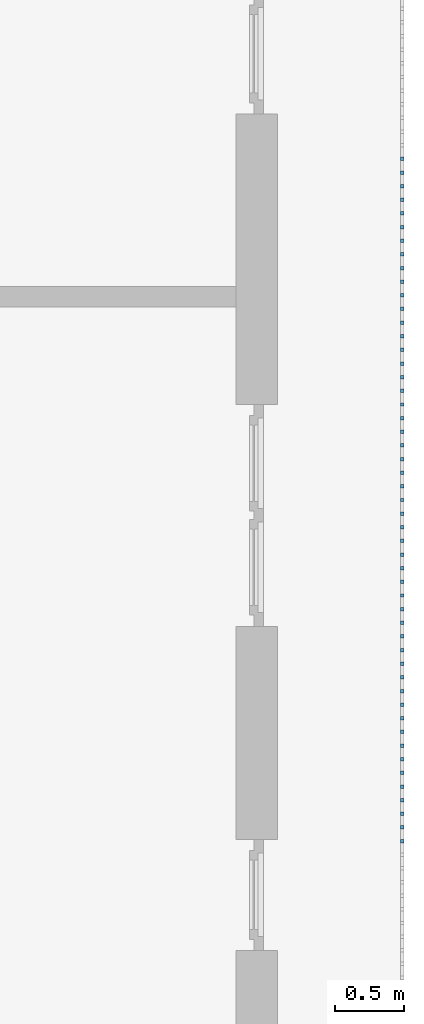
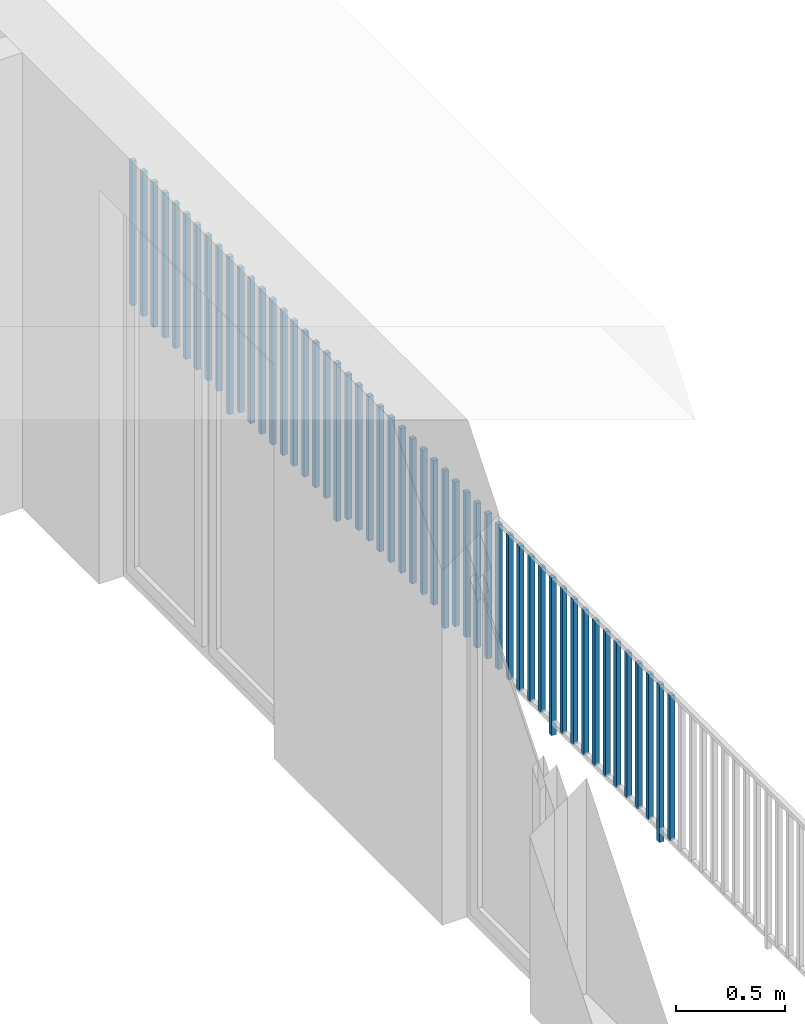
# One storey, part 44 of 54: 51 building element parts, 1 element without a shape of its own.
"""IFC4 building model written with IfcOpenShell, lengths in metres."""

import ifcopenshell
import ifcopenshell.guid

model = None  # the IFC model being written
_history = None  # IfcOwnerHistory: only IFC2X3 demands one
_inside = {}  # id of a spatial element -> (the spatial element, [elements in it])
_under = {}  # id of a project, library or spatial element -> (it, [spatial elements below it])
_declared = {}  # id of a project -> (the project, [libraries it declares])
_typed = {}  # id of a type object -> (the type object, [elements of that type])
_made_of = {}  # id of a material, layer set ... -> (it, [elements and type objects made of it])


def new_model(schema):
    """Start an empty IFC model of exactly this schema.

    Asked for "IFC4X3", IfcOpenShell would pick the latest addendum, in which some entities
    have other attributes; the version numbers below select the first issue.
    IFC2X3 requires an IfcOwnerHistory on every rooted entity: one is made here for all.
    """
    global model, _history
    if schema == "IFC4X3":
        model = ifcopenshell.file(schema_version=(4, 3, 0, 0))
    else:
        model = ifcopenshell.file(schema=schema)
    _inside.clear()
    _under.clear()
    _declared.clear()
    _typed.clear()
    _made_of.clear()
    _history = None
    if model.schema == "IFC2X3":
        org = make("IfcOrganization", Name="unknown")
        user = make(
            "IfcPersonAndOrganization",
            ThePerson=make("IfcPerson", FamilyName="unknown"),
            TheOrganization=org,
        )
        app = make(
            "IfcApplication",
            ApplicationDeveloper=org,
            Version="unknown",
            ApplicationFullName="unknown",
            ApplicationIdentifier="unknown",
        )
        _history = make(
            "IfcOwnerHistory",
            OwningUser=user,
            OwningApplication=app,
            ChangeAction="ADDED",
            CreationDate=0,
        )
    return model


def make(cls, **values):
    """One entity of the class cls with the attributes given. An attribute that is None is left unset."""
    return model.create_entity(
        cls, **{name: value for name, value in values.items() if value is not None}
    )


def entity(cls, *values):
    """Any entity or typed value of the class cls, its attributes in the order of the schema. None: left unset."""
    e = model.create_entity(cls)
    for i, value in enumerate(values):
        if value is not None:
            e[i] = value
    return e


def rooted(cls, **values):
    """An entity with a GlobalId (a new one), such as an element, a storey or a relation."""
    return make(cls, GlobalId=ifcopenshell.guid.new(), OwnerHistory=_history, **values)


def si_unit(unit_type, name, prefix=None):
    """IfcSIUnit, for example si_unit("LENGTHUNIT", "METRE", prefix="MILLI")."""
    return make("IfcSIUnit", UnitType=unit_type, Prefix=prefix, Name=name)


def converted_unit(unit_type, name, factor, base, dimensions=None, offset=None):
    """IfcConversionBasedUnit, such as the inch: factor (a typed value) times the base unit."""
    return make(
        "IfcConversionBasedUnit"
        if offset is None
        else "IfcConversionBasedUnitWithOffset",
        ConversionOffset=offset,
        Dimensions=None
        if dimensions is None
        else entity("IfcDimensionalExponents", *dimensions),
        UnitType=unit_type,
        Name=name,
        ConversionFactor=make(
            "IfcMeasureWithUnit", ValueComponent=factor, UnitComponent=base
        ),
    )


def derived_unit(unit_type, elements):
    """IfcDerivedUnit: a product of units, each with its exponent."""
    return make(
        "IfcDerivedUnit",
        Elements=[
            make("IfcDerivedUnitElement", Unit=unit, Exponent=power)
            for unit, power in elements
        ],
        UnitType=unit_type,
    )


def assignment(units):
    """IfcUnitAssignment: the units of a project."""
    return None if units is None else make("IfcUnitAssignment", Units=units)


def point(xyz):
    """IfcCartesianPoint."""
    return None if xyz is None else make("IfcCartesianPoint", Coordinates=xyz)


def direction(xyz):
    """IfcDirection."""
    return None if xyz is None else make("IfcDirection", DirectionRatios=xyz)


def frame(location, z_axis=None, x_axis=None):
    """IfcAxis2Placement3D, a coordinate frame: its origin and axes. An axis left out is left unset."""
    return make(
        "IfcAxis2Placement3D",
        Location=point(location),
        Axis=direction(z_axis),
        RefDirection=direction(x_axis),
    )


def origin_with_axes():
    """The frame at (0, 0, 0) with the z axis (0, 0, 1) and the x axis (1, 0, 0) written out."""
    return frame((0.0, 0.0, 0.0), z_axis=(0.0, 0.0, 1.0), x_axis=(1.0, 0.0, 0.0))


def place(relative_to, where):
    """IfcLocalPlacement: puts the frame where relative to a parent placement (None: the world)."""
    return make(
        "IfcLocalPlacement", PlacementRelTo=relative_to, RelativePlacement=where
    )


def context(
    kind, dimensions, precision=None, world=None, true_north=None, identifier=None
):
    """IfcGeometricRepresentationContext, for example the 3D "Model" context."""
    return make(
        "IfcGeometricRepresentationContext",
        ContextIdentifier=identifier,
        ContextType=kind,
        CoordinateSpaceDimension=dimensions,
        Precision=precision,
        WorldCoordinateSystem=world,
        TrueNorth=true_north,
    )


def subcontext(parent, identifier, kind, view, scale=None):
    """IfcGeometricRepresentationSubContext, for example "Body" below "Model"."""
    return make(
        "IfcGeometricRepresentationSubContext",
        ContextIdentifier=identifier,
        ContextType=kind,
        ParentContext=parent,
        TargetScale=scale,
        TargetView=view,
    )


def project(units=None, contexts=None):
    """IfcProject with its units and contexts."""
    return rooted(
        "IfcProject",
        Name="project",
        RepresentationContexts=contexts,
        UnitsInContext=assignment(units),
    )


def spatial(cls, under=None, at=None, **own):
    """A site, building, storey or space (cls), placed at a placement, below another one or the project."""
    s = rooted(cls, ObjectPlacement=at, **own)
    if under is not None:
        _under.setdefault(under.id(), (under, []))[1].append(s)
    return s


def point_list(points):
    """IfcCartesianPointList2D or 3D."""
    cls = (
        "IfcCartesianPointList2D" if len(points[0]) == 2 else "IfcCartesianPointList3D"
    )
    return make(cls, CoordList=points)


def polygons(points, faces, closed=None, point_numbers=None):
    """IfcPolygonalFaceSet: a face is its outer loop, then its inner loops; points numbered from 1."""
    made = []
    for loops in faces:
        if len(loops) == 1:
            made.append(make("IfcIndexedPolygonalFace", CoordIndex=loops[0]))
        else:
            made.append(
                make(
                    "IfcIndexedPolygonalFaceWithVoids",
                    CoordIndex=loops[0],
                    InnerCoordIndices=loops[1:],
                )
            )
    return make(
        "IfcPolygonalFaceSet",
        Coordinates=point_list(points),
        Closed=closed,
        Faces=made,
        PnIndex=point_numbers,
    )


def shape(context_of_items, identifier, shape_type, items):
    """IfcShapeRepresentation: the items that make up one representation, for example the "Body"."""
    return make(
        "IfcShapeRepresentation",
        ContextOfItems=context_of_items,
        RepresentationIdentifier=identifier,
        RepresentationType=shape_type,
        Items=items,
    )


def material(Name=None, Category=None):
    """IfcMaterial."""
    return make("IfcMaterial", Name=Name, Category=Category)


def made_of(thing, what):
    """Note that an element or type object is made of a material, layer set ...; save() writes the relation."""
    if what is not None:
        _made_of.setdefault(what.id(), (what, []))[1].append(thing)
    return thing


def type_object(cls, material=None, **own):
    """A type object (cls), such as IfcWallType, which elements share."""
    return made_of(rooted(cls, **own), material)


def element(
    cls,
    number,
    at=None,
    inside=None,
    cuts=None,
    type_object=None,
    material=None,
    context=None,
    identifier="Body",
    shape_type=None,
    held_by="IfcProductDefinitionShape",
    body=None,
    shapes=None,
    **own,
):
    """One element of the class cls, such as IfcWall. Its Tag is "e" and its number.

    at: its placement. inside: the storey or other place that contains it. cuts: it is an
    opening in that element (IfcRelVoidsElement). A single representation is given by context,
    identifier, shape_type and body (its items); several are given by shapes. held_by: the class
    of the entity that holds the representations. save() writes the other relations.
    """
    e = rooted(cls, Tag="e%d" % number, ObjectPlacement=at, **own)
    if body is not None:
        shapes = [shape(context, identifier, shape_type, body)]
    if shapes is not None:
        e.Representation = make(held_by, Representations=shapes)
    if inside is not None:
        _inside.setdefault(inside.id(), (inside, []))[1].append(e)
    if cuts is not None:
        rooted(
            "IfcRelVoidsElement", RelatingBuildingElement=cuts, RelatedOpeningElement=e
        )
    if type_object is not None:
        _typed.setdefault(type_object.id(), (type_object, []))[1].append(e)
    return made_of(e, material)


def aggregate(whole, parts):
    """IfcRelAggregates: a whole, such as a stair, and the parts it consists of."""
    return rooted("IfcRelAggregates", RelatingObject=whole, RelatedObjects=parts)


def save(model, path):
    """Write the relations noted so far, then the file.

    IfcRelAggregates (storeys below a building ...), IfcRelContainedInSpatialStructure (elements
    in a storey), IfcRelDefinesByType, IfcRelAssociatesMaterial and IfcRelDeclares: one each for
    every whole, place, type object, material and project.
    """
    for whole, parts in _under.values():
        aggregate(whole, parts)
    for where, things in _inside.values():
        rooted(
            "IfcRelContainedInSpatialStructure",
            RelatedElements=things,
            RelatingStructure=where,
        )
    for kind, things in _typed.values():
        rooted("IfcRelDefinesByType", RelatedObjects=things, RelatingType=kind)
    for what, things in _made_of.values():
        rooted("IfcRelAssociatesMaterial", RelatedObjects=things, RelatingMaterial=what)
    for by, libraries in _declared.values():
        rooted("IfcRelDeclares", RelatingContext=by, RelatedDefinitions=libraries)
    model.write(path)


model = new_model("IFC4")

# Units and contexts
model_context = context("Model", 3, precision=1e-05, world=origin_with_axes(), true_north=direction((0.0, 1.0)))
body_context = subcontext(model_context, "Body", "Model", "MODEL_VIEW")
ifc_project = project(units=[si_unit("LENGTHUNIT", "METRE"), si_unit("AREAUNIT", "SQUARE_METRE"), si_unit("VOLUMEUNIT", "CUBIC_METRE"), converted_unit("PLANEANGLEUNIT", "DEGREE", entity("IfcPlaneAngleMeasure", 0.0174532925199), si_unit("PLANEANGLEUNIT", "RADIAN"), dimensions=[0, 0, 0, 0, 0, 0, 0]), converted_unit("TIMEUNIT", "Year", entity("IfcTimeMeasure", 31556926.0), si_unit("TIMEUNIT", "SECOND"), dimensions=[0, 0, 1, 0, 0, 0, 0]), si_unit("MASSUNIT", "GRAM", prefix="KILO"), si_unit("THERMODYNAMICTEMPERATUREUNIT", "DEGREE_CELSIUS"), si_unit("LUMINOUSINTENSITYUNIT", "LUMEN"), si_unit("ENERGYUNIT", "JOULE", prefix="MEGA"), derived_unit("THERMALCONDUCTANCEUNIT", [(si_unit("POWERUNIT", "WATT"), 1), (si_unit("LENGTHUNIT", "METRE"), -1), (si_unit("THERMODYNAMICTEMPERATUREUNIT", "KELVIN"), -1)]), derived_unit("SPECIFICHEATCAPACITYUNIT", [(si_unit("ENERGYUNIT", "JOULE"), 1), (si_unit("MASSUNIT", "GRAM", prefix="KILO"), -1), (si_unit("THERMODYNAMICTEMPERATUREUNIT", "KELVIN"), -1)]), derived_unit("MASSDENSITYUNIT", [(si_unit("MASSUNIT", "GRAM", prefix="KILO"), 1), (si_unit("VOLUMEUNIT", "CUBIC_METRE"), -1)])], contexts=[model_context])

# Site, building, storey, space
site_placement = place(None, origin_with_axes())
site = spatial("IfcSite", under=ifc_project, at=site_placement, CompositionType="ELEMENT")
building_placement = place(site_placement, origin_with_axes())
building = spatial("IfcBuilding", under=site, at=building_placement, CompositionType="ELEMENT")
storey_placement = place(building_placement, frame((0.0, 0.0, 6.29), z_axis=(0.0, 0.0, 1.0), x_axis=(1.0, 0.0, 0.0)))
storey = spatial("IfcBuildingStorey", under=building, at=storey_placement, Name="2. Geschoss", CompositionType="ELEMENT", Elevation=6.29)
space_placement = place(storey_placement, frame((10.2378006196, 9.82118769833, 0.0), z_axis=(0.0, 0.0, 1.0), x_axis=(-1.0, 0.0, 0.0)))
space = spatial("IfcSpace", under=storey, at=space_placement, CompositionType="ELEMENT", PredefinedType="EXTERNAL")

# Railing, building element parts
railing_type = type_object("IfcRailingType", PredefinedType="NOTDEFINED")
railing_placement = place(space_placement, frame((0.0, -7.06315681498e-08, 0.0), z_axis=(0.0, 0.0, 1.0), x_axis=(-1.0, 0.0, 0.0)))
railing = element("IfcRailing", 1, at=railing_placement, inside=space, type_object=railing_type, PredefinedType="NOTDEFINED")
ifc_material = material()
building_element_part_1_placement = place(railing_placement, origin_with_axes())
building_element_part_1 = element("IfcBuildingElementPart", 2, at=building_element_part_1_placement, material=ifc_material, PredefinedType="NOTDEFINED", context=body_context, shape_type="Tessellation", body=[
    polygons([(0.0125, -17.7858333333, 0.07), (-0.0125, -17.7858333333, 0.07), (-0.0125, -17.7858333333, 0.8775), (0.0125, -17.7858333333, 0.8775), (0.0125, -17.8108333333, 0.07), (-0.0125, -17.8108333333, 0.07), (-0.0125, -17.8108333333, 0.8775), (0.0125, -17.8108333333, 0.8775)], [[[1, 2, 3, 4]], [[1, 5, 6, 2]], [[2, 6, 7, 3]], [[4, 3, 7, 8]], [[5, 1, 4, 8]], [[6, 5, 8, 7]]], closed=True),
])
building_element_part_2_placement = place(railing_placement, origin_with_axes())
building_element_part_2 = element("IfcBuildingElementPart", 3, at=building_element_part_2_placement, material=ifc_material, PredefinedType="NOTDEFINED", context=body_context, shape_type="Tessellation", body=[
    polygons([(0.0125, -17.6875, 0.0), (-0.0125, -17.6875, 0.0), (-0.0125, -17.6875, 0.88), (0.0125, -17.6875, 0.88), (0.0125, -17.7125, 0.0), (-0.0125, -17.7125, 0.0), (-0.0125, -17.7125, 0.88), (0.0125, -17.7125, 0.88)], [[[1, 2, 3, 4]], [[1, 5, 6, 2]], [[2, 6, 7, 3]], [[4, 3, 7, 8]], [[5, 1, 4, 8]], [[6, 5, 8, 7]]], closed=True),
])
building_element_part_3_placement = place(railing_placement, origin_with_axes())
building_element_part_3 = element("IfcBuildingElementPart", 4, at=building_element_part_3_placement, material=ifc_material, PredefinedType="NOTDEFINED", context=body_context, shape_type="Tessellation", body=[
    polygons([(0.0125, -17.5891666667, 0.07), (-0.0125, -17.5891666667, 0.07), (-0.0125, -17.5891666667, 0.8775), (0.0125, -17.5891666667, 0.8775), (0.0125, -17.6141666667, 0.07), (-0.0125, -17.6141666667, 0.07), (-0.0125, -17.6141666667, 0.8775), (0.0125, -17.6141666667, 0.8775)], [[[1, 2, 3, 4]], [[1, 5, 6, 2]], [[2, 6, 7, 3]], [[4, 3, 7, 8]], [[5, 1, 4, 8]], [[6, 5, 8, 7]]], closed=True),
])
building_element_part_4_placement = place(railing_placement, origin_with_axes())
building_element_part_4 = element("IfcBuildingElementPart", 5, at=building_element_part_4_placement, material=ifc_material, PredefinedType="NOTDEFINED", context=body_context, shape_type="Tessellation", body=[
    polygons([(0.0125, -17.4908333333, 0.07), (-0.0125, -17.4908333333, 0.07), (-0.0125, -17.4908333333, 0.8775), (0.0125, -17.4908333333, 0.8775), (0.0125, -17.5158333333, 0.07), (-0.0125, -17.5158333333, 0.07), (-0.0125, -17.5158333333, 0.8775), (0.0125, -17.5158333333, 0.8775)], [[[1, 2, 3, 4]], [[1, 5, 6, 2]], [[2, 6, 7, 3]], [[4, 3, 7, 8]], [[5, 1, 4, 8]], [[6, 5, 8, 7]]], closed=True),
])
building_element_part_5_placement = place(railing_placement, origin_with_axes())
building_element_part_5 = element("IfcBuildingElementPart", 6, at=building_element_part_5_placement, material=ifc_material, PredefinedType="NOTDEFINED", context=body_context, shape_type="Tessellation", body=[
    polygons([(0.0125, -17.3925, 0.07), (-0.0125, -17.3925, 0.07), (-0.0125, -17.3925, 0.8775), (0.0125, -17.3925, 0.8775), (0.0125, -17.4175, 0.07), (-0.0125, -17.4175, 0.07), (-0.0125, -17.4175, 0.8775), (0.0125, -17.4175, 0.8775)], [[[1, 2, 3, 4]], [[1, 5, 6, 2]], [[2, 6, 7, 3]], [[4, 3, 7, 8]], [[5, 1, 4, 8]], [[6, 5, 8, 7]]], closed=True),
])
building_element_part_6_placement = place(railing_placement, origin_with_axes())
building_element_part_6 = element("IfcBuildingElementPart", 7, at=building_element_part_6_placement, material=ifc_material, PredefinedType="NOTDEFINED", context=body_context, shape_type="Tessellation", body=[
    polygons([(0.0125, -17.2941666667, 0.07), (-0.0125, -17.2941666667, 0.07), (-0.0125, -17.2941666667, 0.8775), (0.0125, -17.2941666667, 0.8775), (0.0125, -17.3191666667, 0.07), (-0.0125, -17.3191666667, 0.07), (-0.0125, -17.3191666667, 0.8775), (0.0125, -17.3191666667, 0.8775)], [[[1, 2, 3, 4]], [[1, 5, 6, 2]], [[2, 6, 7, 3]], [[4, 3, 7, 8]], [[5, 1, 4, 8]], [[6, 5, 8, 7]]], closed=True),
])
building_element_part_7_placement = place(railing_placement, origin_with_axes())
building_element_part_7 = element("IfcBuildingElementPart", 8, at=building_element_part_7_placement, material=ifc_material, PredefinedType="NOTDEFINED", context=body_context, shape_type="Tessellation", body=[
    polygons([(0.0125, -17.1958333333, 0.07), (-0.0125, -17.1958333333, 0.07), (-0.0125, -17.1958333333, 0.8775), (0.0125, -17.1958333333, 0.8775), (0.0125, -17.2208333333, 0.07), (-0.0125, -17.2208333333, 0.07), (-0.0125, -17.2208333333, 0.8775), (0.0125, -17.2208333333, 0.8775)], [[[1, 2, 3, 4]], [[1, 5, 6, 2]], [[2, 6, 7, 3]], [[4, 3, 7, 8]], [[5, 1, 4, 8]], [[6, 5, 8, 7]]], closed=True),
])
building_element_part_8_placement = place(railing_placement, origin_with_axes())
building_element_part_8 = element("IfcBuildingElementPart", 9, at=building_element_part_8_placement, material=ifc_material, PredefinedType="NOTDEFINED", context=body_context, shape_type="Tessellation", body=[
    polygons([(0.0125, -17.0975, 0.07), (-0.0125, -17.0975, 0.07), (-0.0125, -17.0975, 0.8775), (0.0125, -17.0975, 0.8775), (0.0125, -17.1225, 0.07), (-0.0125, -17.1225, 0.07), (-0.0125, -17.1225, 0.8775), (0.0125, -17.1225, 0.8775)], [[[1, 2, 3, 4]], [[1, 5, 6, 2]], [[2, 6, 7, 3]], [[4, 3, 7, 8]], [[5, 1, 4, 8]], [[6, 5, 8, 7]]], closed=True),
])
building_element_part_9_placement = place(railing_placement, origin_with_axes())
building_element_part_9 = element("IfcBuildingElementPart", 10, at=building_element_part_9_placement, material=ifc_material, PredefinedType="NOTDEFINED", context=body_context, shape_type="Tessellation", body=[
    polygons([(0.0125, -16.9991666667, 0.07), (-0.0125, -16.9991666667, 0.07), (-0.0125, -16.9991666667, 0.8775), (0.0125, -16.9991666667, 0.8775), (0.0125, -17.0241666667, 0.07), (-0.0125, -17.0241666667, 0.07), (-0.0125, -17.0241666667, 0.8775), (0.0125, -17.0241666667, 0.8775)], [[[1, 2, 3, 4]], [[1, 5, 6, 2]], [[2, 6, 7, 3]], [[4, 3, 7, 8]], [[5, 1, 4, 8]], [[6, 5, 8, 7]]], closed=True),
])
building_element_part_10_placement = place(railing_placement, origin_with_axes())
building_element_part_10 = element("IfcBuildingElementPart", 11, at=building_element_part_10_placement, material=ifc_material, PredefinedType="NOTDEFINED", context=body_context, shape_type="Tessellation", body=[
    polygons([(0.0125, -16.9008333333, 0.07), (-0.0125, -16.9008333333, 0.07), (-0.0125, -16.9008333333, 0.8775), (0.0125, -16.9008333333, 0.8775), (0.0125, -16.9258333333, 0.07), (-0.0125, -16.9258333333, 0.07), (-0.0125, -16.9258333333, 0.8775), (0.0125, -16.9258333333, 0.8775)], [[[1, 2, 3, 4]], [[1, 5, 6, 2]], [[2, 6, 7, 3]], [[4, 3, 7, 8]], [[5, 1, 4, 8]], [[6, 5, 8, 7]]], closed=True),
])
building_element_part_11_placement = place(railing_placement, origin_with_axes())
building_element_part_11 = element("IfcBuildingElementPart", 12, at=building_element_part_11_placement, material=ifc_material, PredefinedType="NOTDEFINED", context=body_context, shape_type="Tessellation", body=[
    polygons([(0.0125, -16.8025, 0.07), (-0.0125, -16.8025, 0.07), (-0.0125, -16.8025, 0.8775), (0.0125, -16.8025, 0.8775), (0.0125, -16.8275, 0.07), (-0.0125, -16.8275, 0.07), (-0.0125, -16.8275, 0.8775), (0.0125, -16.8275, 0.8775)], [[[1, 2, 3, 4]], [[1, 5, 6, 2]], [[2, 6, 7, 3]], [[4, 3, 7, 8]], [[5, 1, 4, 8]], [[6, 5, 8, 7]]], closed=True),
])
building_element_part_12_placement = place(railing_placement, origin_with_axes())
building_element_part_12 = element("IfcBuildingElementPart", 13, at=building_element_part_12_placement, material=ifc_material, PredefinedType="NOTDEFINED", context=body_context, shape_type="Tessellation", body=[
    polygons([(0.0125, -16.7041666667, 0.0), (-0.0125, -16.7041666667, 0.0), (-0.0125, -16.7041666667, 0.88), (0.0125, -16.7041666667, 0.88), (0.0125, -16.7291666667, 0.0), (-0.0125, -16.7291666667, 0.0), (-0.0125, -16.7291666667, 0.88), (0.0125, -16.7291666667, 0.88)], [[[1, 2, 3, 4]], [[1, 5, 6, 2]], [[2, 6, 7, 3]], [[4, 3, 7, 8]], [[5, 1, 4, 8]], [[6, 5, 8, 7]]], closed=True),
])
building_element_part_13_placement = place(railing_placement, origin_with_axes())
building_element_part_13 = element("IfcBuildingElementPart", 14, at=building_element_part_13_placement, material=ifc_material, PredefinedType="NOTDEFINED", context=body_context, shape_type="Tessellation", body=[
    polygons([(0.0125, -16.6058333333, 0.07), (-0.0125, -16.6058333333, 0.07), (-0.0125, -16.6058333333, 0.8775), (0.0125, -16.6058333333, 0.8775), (0.0125, -16.6308333333, 0.07), (-0.0125, -16.6308333333, 0.07), (-0.0125, -16.6308333333, 0.8775), (0.0125, -16.6308333333, 0.8775)], [[[1, 2, 3, 4]], [[1, 5, 6, 2]], [[2, 6, 7, 3]], [[4, 3, 7, 8]], [[5, 1, 4, 8]], [[6, 5, 8, 7]]], closed=True),
])
building_element_part_14_placement = place(railing_placement, origin_with_axes())
building_element_part_14 = element("IfcBuildingElementPart", 15, at=building_element_part_14_placement, material=ifc_material, PredefinedType="NOTDEFINED", context=body_context, shape_type="Tessellation", body=[
    polygons([(0.0125, -16.5075, 0.07), (-0.0125, -16.5075, 0.07), (-0.0125, -16.5075, 0.8775), (0.0125, -16.5075, 0.8775), (0.0125, -16.5325, 0.07), (-0.0125, -16.5325, 0.07), (-0.0125, -16.5325, 0.8775), (0.0125, -16.5325, 0.8775)], [[[1, 2, 3, 4]], [[1, 5, 6, 2]], [[2, 6, 7, 3]], [[4, 3, 7, 8]], [[5, 1, 4, 8]], [[6, 5, 8, 7]]], closed=True),
])
building_element_part_15_placement = place(railing_placement, origin_with_axes())
building_element_part_15 = element("IfcBuildingElementPart", 16, at=building_element_part_15_placement, material=ifc_material, PredefinedType="NOTDEFINED", context=body_context, shape_type="Tessellation", body=[
    polygons([(0.0125, -16.4091666667, 0.07), (-0.0125, -16.4091666667, 0.07), (-0.0125, -16.4091666667, 0.8775), (0.0125, -16.4091666667, 0.8775), (0.0125, -16.4341666667, 0.07), (-0.0125, -16.4341666667, 0.07), (-0.0125, -16.4341666667, 0.8775), (0.0125, -16.4341666667, 0.8775)], [[[1, 2, 3, 4]], [[1, 5, 6, 2]], [[2, 6, 7, 3]], [[4, 3, 7, 8]], [[5, 1, 4, 8]], [[6, 5, 8, 7]]], closed=True),
])
building_element_part_16_placement = place(railing_placement, origin_with_axes())
building_element_part_16 = element("IfcBuildingElementPart", 17, at=building_element_part_16_placement, material=ifc_material, PredefinedType="NOTDEFINED", context=body_context, shape_type="Tessellation", body=[
    polygons([(0.0125, -16.3108333333, 0.07), (-0.0125, -16.3108333333, 0.07), (-0.0125, -16.3108333333, 0.8775), (0.0125, -16.3108333333, 0.8775), (0.0125, -16.3358333333, 0.07), (-0.0125, -16.3358333333, 0.07), (-0.0125, -16.3358333333, 0.8775), (0.0125, -16.3358333333, 0.8775)], [[[1, 2, 3, 4]], [[1, 5, 6, 2]], [[2, 6, 7, 3]], [[4, 3, 7, 8]], [[5, 1, 4, 8]], [[6, 5, 8, 7]]], closed=True),
])
building_element_part_17_placement = place(railing_placement, origin_with_axes())
building_element_part_17 = element("IfcBuildingElementPart", 18, at=building_element_part_17_placement, material=ifc_material, PredefinedType="NOTDEFINED", context=body_context, shape_type="Tessellation", body=[
    polygons([(0.0125, -16.2125, 0.07), (-0.0125, -16.2125, 0.07), (-0.0125, -16.2125, 0.8775), (0.0125, -16.2125, 0.8775), (0.0125, -16.2375, 0.07), (-0.0125, -16.2375, 0.07), (-0.0125, -16.2375, 0.8775), (0.0125, -16.2375, 0.8775)], [[[1, 2, 3, 4]], [[1, 5, 6, 2]], [[2, 6, 7, 3]], [[4, 3, 7, 8]], [[5, 1, 4, 8]], [[6, 5, 8, 7]]], closed=True),
])
building_element_part_18_placement = place(railing_placement, origin_with_axes())
building_element_part_18 = element("IfcBuildingElementPart", 19, at=building_element_part_18_placement, material=ifc_material, PredefinedType="NOTDEFINED", context=body_context, shape_type="Tessellation", body=[
    polygons([(0.0125, -16.1141666667, 0.07), (-0.0125, -16.1141666667, 0.07), (-0.0125, -16.1141666667, 0.8775), (0.0125, -16.1141666667, 0.8775), (0.0125, -16.1391666667, 0.07), (-0.0125, -16.1391666667, 0.07), (-0.0125, -16.1391666667, 0.8775), (0.0125, -16.1391666667, 0.8775)], [[[1, 2, 3, 4]], [[1, 5, 6, 2]], [[2, 6, 7, 3]], [[4, 3, 7, 8]], [[5, 1, 4, 8]], [[6, 5, 8, 7]]], closed=True),
])
building_element_part_19_placement = place(railing_placement, origin_with_axes())
building_element_part_19 = element("IfcBuildingElementPart", 20, at=building_element_part_19_placement, material=ifc_material, PredefinedType="NOTDEFINED", context=body_context, shape_type="Tessellation", body=[
    polygons([(0.0125, -16.0158333333, 0.07), (-0.0125, -16.0158333333, 0.07), (-0.0125, -16.0158333333, 0.8775), (0.0125, -16.0158333333, 0.8775), (0.0125, -16.0408333333, 0.07), (-0.0125, -16.0408333333, 0.07), (-0.0125, -16.0408333333, 0.8775), (0.0125, -16.0408333333, 0.8775)], [[[1, 2, 3, 4]], [[1, 5, 6, 2]], [[2, 6, 7, 3]], [[4, 3, 7, 8]], [[5, 1, 4, 8]], [[6, 5, 8, 7]]], closed=True),
])
building_element_part_20_placement = place(railing_placement, origin_with_axes())
building_element_part_20 = element("IfcBuildingElementPart", 21, at=building_element_part_20_placement, material=ifc_material, PredefinedType="NOTDEFINED", context=body_context, shape_type="Tessellation", body=[
    polygons([(0.0125, -15.9175, 0.07), (-0.0125, -15.9175, 0.07), (-0.0125, -15.9175, 0.8775), (0.0125, -15.9175, 0.8775), (0.0125, -15.9425, 0.07), (-0.0125, -15.9425, 0.07), (-0.0125, -15.9425, 0.8775), (0.0125, -15.9425, 0.8775)], [[[1, 2, 3, 4]], [[1, 5, 6, 2]], [[2, 6, 7, 3]], [[4, 3, 7, 8]], [[5, 1, 4, 8]], [[6, 5, 8, 7]]], closed=True),
])
building_element_part_21_placement = place(railing_placement, origin_with_axes())
building_element_part_21 = element("IfcBuildingElementPart", 22, at=building_element_part_21_placement, material=ifc_material, PredefinedType="NOTDEFINED", context=body_context, shape_type="Tessellation", body=[
    polygons([(0.0125, -15.8191666667, 0.07), (-0.0125, -15.8191666667, 0.07), (-0.0125, -15.8191666667, 0.8775), (0.0125, -15.8191666667, 0.8775), (0.0125, -15.8441666667, 0.07), (-0.0125, -15.8441666667, 0.07), (-0.0125, -15.8441666667, 0.8775), (0.0125, -15.8441666667, 0.8775)], [[[1, 2, 3, 4]], [[1, 5, 6, 2]], [[2, 6, 7, 3]], [[4, 3, 7, 8]], [[5, 1, 4, 8]], [[6, 5, 8, 7]]], closed=True),
])
building_element_part_22_placement = place(railing_placement, origin_with_axes())
building_element_part_22 = element("IfcBuildingElementPart", 23, at=building_element_part_22_placement, material=ifc_material, PredefinedType="NOTDEFINED", context=body_context, shape_type="Tessellation", body=[
    polygons([(0.0125, -15.7208333333, 0.0), (-0.0125, -15.7208333333, 0.0), (-0.0125, -15.7208333333, 0.88), (0.0125, -15.7208333333, 0.88), (0.0125, -15.7458333333, 0.0), (-0.0125, -15.7458333333, 0.0), (-0.0125, -15.7458333333, 0.88), (0.0125, -15.7458333333, 0.88)], [[[1, 2, 3, 4]], [[1, 5, 6, 2]], [[2, 6, 7, 3]], [[4, 3, 7, 8]], [[5, 1, 4, 8]], [[6, 5, 8, 7]]], closed=True),
])
building_element_part_23_placement = place(railing_placement, origin_with_axes())
building_element_part_23 = element("IfcBuildingElementPart", 24, at=building_element_part_23_placement, material=ifc_material, PredefinedType="NOTDEFINED", context=body_context, shape_type="Tessellation", body=[
    polygons([(0.0125, -15.6225, 0.07), (-0.0125, -15.6225, 0.07), (-0.0125, -15.6225, 0.8775), (0.0125, -15.6225, 0.8775), (0.0125, -15.6475, 0.07), (-0.0125, -15.6475, 0.07), (-0.0125, -15.6475, 0.8775), (0.0125, -15.6475, 0.8775)], [[[1, 2, 3, 4]], [[1, 5, 6, 2]], [[2, 6, 7, 3]], [[4, 3, 7, 8]], [[5, 1, 4, 8]], [[6, 5, 8, 7]]], closed=True),
])
building_element_part_24_placement = place(railing_placement, origin_with_axes())
building_element_part_24 = element("IfcBuildingElementPart", 25, at=building_element_part_24_placement, material=ifc_material, PredefinedType="NOTDEFINED", context=body_context, shape_type="Tessellation", body=[
    polygons([(0.0125, -15.5241666667, 0.07), (-0.0125, -15.5241666667, 0.07), (-0.0125, -15.5241666667, 0.8775), (0.0125, -15.5241666667, 0.8775), (0.0125, -15.5491666667, 0.07), (-0.0125, -15.5491666667, 0.07), (-0.0125, -15.5491666667, 0.8775), (0.0125, -15.5491666667, 0.8775)], [[[1, 2, 3, 4]], [[1, 5, 6, 2]], [[2, 6, 7, 3]], [[4, 3, 7, 8]], [[5, 1, 4, 8]], [[6, 5, 8, 7]]], closed=True),
])
building_element_part_25_placement = place(railing_placement, origin_with_axes())
building_element_part_25 = element("IfcBuildingElementPart", 26, at=building_element_part_25_placement, material=ifc_material, PredefinedType="NOTDEFINED", context=body_context, shape_type="Tessellation", body=[
    polygons([(0.0125, -15.4258333333, 0.07), (-0.0125, -15.4258333333, 0.07), (-0.0125, -15.4258333333, 0.8775), (0.0125, -15.4258333333, 0.8775), (0.0125, -15.4508333333, 0.07), (-0.0125, -15.4508333333, 0.07), (-0.0125, -15.4508333333, 0.8775), (0.0125, -15.4508333333, 0.8775)], [[[1, 2, 3, 4]], [[1, 5, 6, 2]], [[2, 6, 7, 3]], [[4, 3, 7, 8]], [[5, 1, 4, 8]], [[6, 5, 8, 7]]], closed=True),
])
building_element_part_26_placement = place(railing_placement, origin_with_axes())
building_element_part_26 = element("IfcBuildingElementPart", 27, at=building_element_part_26_placement, material=ifc_material, PredefinedType="NOTDEFINED", context=body_context, shape_type="Tessellation", body=[
    polygons([(0.0125, -15.3275, 0.07), (-0.0125, -15.3275, 0.07), (-0.0125, -15.3275, 0.8775), (0.0125, -15.3275, 0.8775), (0.0125, -15.3525, 0.07), (-0.0125, -15.3525, 0.07), (-0.0125, -15.3525, 0.8775), (0.0125, -15.3525, 0.8775)], [[[1, 2, 3, 4]], [[1, 5, 6, 2]], [[2, 6, 7, 3]], [[4, 3, 7, 8]], [[5, 1, 4, 8]], [[6, 5, 8, 7]]], closed=True),
])
building_element_part_27_placement = place(railing_placement, origin_with_axes())
building_element_part_27 = element("IfcBuildingElementPart", 28, at=building_element_part_27_placement, material=ifc_material, PredefinedType="NOTDEFINED", context=body_context, shape_type="Tessellation", body=[
    polygons([(0.0125, -15.2291666667, 0.07), (-0.0125, -15.2291666667, 0.07), (-0.0125, -15.2291666667, 0.8775), (0.0125, -15.2291666667, 0.8775), (0.0125, -15.2541666667, 0.07), (-0.0125, -15.2541666667, 0.07), (-0.0125, -15.2541666667, 0.8775), (0.0125, -15.2541666667, 0.8775)], [[[1, 2, 3, 4]], [[1, 5, 6, 2]], [[2, 6, 7, 3]], [[4, 3, 7, 8]], [[5, 1, 4, 8]], [[6, 5, 8, 7]]], closed=True),
])
building_element_part_28_placement = place(railing_placement, origin_with_axes())
building_element_part_28 = element("IfcBuildingElementPart", 29, at=building_element_part_28_placement, material=ifc_material, PredefinedType="NOTDEFINED", context=body_context, shape_type="Tessellation", body=[
    polygons([(0.0125, -15.1308333333, 0.07), (-0.0125, -15.1308333333, 0.07), (-0.0125, -15.1308333333, 0.8775), (0.0125, -15.1308333333, 0.8775), (0.0125, -15.1558333333, 0.07), (-0.0125, -15.1558333333, 0.07), (-0.0125, -15.1558333333, 0.8775), (0.0125, -15.1558333333, 0.8775)], [[[1, 2, 3, 4]], [[1, 5, 6, 2]], [[2, 6, 7, 3]], [[4, 3, 7, 8]], [[5, 1, 4, 8]], [[6, 5, 8, 7]]], closed=True),
])
building_element_part_29_placement = place(railing_placement, origin_with_axes())
building_element_part_29 = element("IfcBuildingElementPart", 30, at=building_element_part_29_placement, material=ifc_material, PredefinedType="NOTDEFINED", context=body_context, shape_type="Tessellation", body=[
    polygons([(0.0125, -15.0325, 0.07), (-0.0125, -15.0325, 0.07), (-0.0125, -15.0325, 0.8775), (0.0125, -15.0325, 0.8775), (0.0125, -15.0575, 0.07), (-0.0125, -15.0575, 0.07), (-0.0125, -15.0575, 0.8775), (0.0125, -15.0575, 0.8775)], [[[1, 2, 3, 4]], [[1, 5, 6, 2]], [[2, 6, 7, 3]], [[4, 3, 7, 8]], [[5, 1, 4, 8]], [[6, 5, 8, 7]]], closed=True),
])
building_element_part_30_placement = place(railing_placement, origin_with_axes())
building_element_part_30 = element("IfcBuildingElementPart", 31, at=building_element_part_30_placement, material=ifc_material, PredefinedType="NOTDEFINED", context=body_context, shape_type="Tessellation", body=[
    polygons([(0.0125, -14.9341666667, 0.07), (-0.0125, -14.9341666667, 0.07), (-0.0125, -14.9341666667, 0.8775), (0.0125, -14.9341666667, 0.8775), (0.0125, -14.9591666667, 0.07), (-0.0125, -14.9591666667, 0.07), (-0.0125, -14.9591666667, 0.8775), (0.0125, -14.9591666667, 0.8775)], [[[1, 2, 3, 4]], [[1, 5, 6, 2]], [[2, 6, 7, 3]], [[4, 3, 7, 8]], [[5, 1, 4, 8]], [[6, 5, 8, 7]]], closed=True),
])
building_element_part_31_placement = place(railing_placement, origin_with_axes())
building_element_part_31 = element("IfcBuildingElementPart", 32, at=building_element_part_31_placement, material=ifc_material, PredefinedType="NOTDEFINED", context=body_context, shape_type="Tessellation", body=[
    polygons([(0.0125, -14.8358333333, 0.07), (-0.0125, -14.8358333333, 0.07), (-0.0125, -14.8358333333, 0.8775), (0.0125, -14.8358333333, 0.8775), (0.0125, -14.8608333333, 0.07), (-0.0125, -14.8608333333, 0.07), (-0.0125, -14.8608333333, 0.8775), (0.0125, -14.8608333333, 0.8775)], [[[1, 2, 3, 4]], [[1, 5, 6, 2]], [[2, 6, 7, 3]], [[4, 3, 7, 8]], [[5, 1, 4, 8]], [[6, 5, 8, 7]]], closed=True),
])
building_element_part_32_placement = place(railing_placement, origin_with_axes())
building_element_part_32 = element("IfcBuildingElementPart", 33, at=building_element_part_32_placement, material=ifc_material, PredefinedType="NOTDEFINED", context=body_context, shape_type="Tessellation", body=[
    polygons([(0.0125, -14.7375, 0.0), (-0.0125, -14.7375, 0.0), (-0.0125, -14.7375, 0.88), (0.0125, -14.7375, 0.88), (0.0125, -14.7625, 0.0), (-0.0125, -14.7625, 0.0), (-0.0125, -14.7625, 0.88), (0.0125, -14.7625, 0.88)], [[[1, 2, 3, 4]], [[1, 5, 6, 2]], [[2, 6, 7, 3]], [[4, 3, 7, 8]], [[5, 1, 4, 8]], [[6, 5, 8, 7]]], closed=True),
])
building_element_part_33_placement = place(railing_placement, origin_with_axes())
building_element_part_33 = element("IfcBuildingElementPart", 34, at=building_element_part_33_placement, material=ifc_material, PredefinedType="NOTDEFINED", context=body_context, shape_type="Tessellation", body=[
    polygons([(0.0125, -14.6391666667, 0.07), (-0.0125, -14.6391666667, 0.07), (-0.0125, -14.6391666667, 0.8775), (0.0125, -14.6391666667, 0.8775), (0.0125, -14.6641666667, 0.07), (-0.0125, -14.6641666667, 0.07), (-0.0125, -14.6641666667, 0.8775), (0.0125, -14.6641666667, 0.8775)], [[[1, 2, 3, 4]], [[1, 5, 6, 2]], [[2, 6, 7, 3]], [[4, 3, 7, 8]], [[5, 1, 4, 8]], [[6, 5, 8, 7]]], closed=True),
])
building_element_part_34_placement = place(railing_placement, origin_with_axes())
building_element_part_34 = element("IfcBuildingElementPart", 35, at=building_element_part_34_placement, material=ifc_material, PredefinedType="NOTDEFINED", context=body_context, shape_type="Tessellation", body=[
    polygons([(0.0125, -14.5408333333, 0.07), (-0.0125, -14.5408333333, 0.07), (-0.0125, -14.5408333333, 0.8775), (0.0125, -14.5408333333, 0.8775), (0.0125, -14.5658333333, 0.07), (-0.0125, -14.5658333333, 0.07), (-0.0125, -14.5658333333, 0.8775), (0.0125, -14.5658333333, 0.8775)], [[[1, 2, 3, 4]], [[1, 5, 6, 2]], [[2, 6, 7, 3]], [[4, 3, 7, 8]], [[5, 1, 4, 8]], [[6, 5, 8, 7]]], closed=True),
])
building_element_part_35_placement = place(railing_placement, origin_with_axes())
building_element_part_35 = element("IfcBuildingElementPart", 36, at=building_element_part_35_placement, material=ifc_material, PredefinedType="NOTDEFINED", context=body_context, shape_type="Tessellation", body=[
    polygons([(0.0125, -14.4425, 0.07), (-0.0125, -14.4425, 0.07), (-0.0125, -14.4425, 0.8775), (0.0125, -14.4425, 0.8775), (0.0125, -14.4675, 0.07), (-0.0125, -14.4675, 0.07), (-0.0125, -14.4675, 0.8775), (0.0125, -14.4675, 0.8775)], [[[1, 2, 3, 4]], [[1, 5, 6, 2]], [[2, 6, 7, 3]], [[4, 3, 7, 8]], [[5, 1, 4, 8]], [[6, 5, 8, 7]]], closed=True),
])
building_element_part_36_placement = place(railing_placement, origin_with_axes())
building_element_part_36 = element("IfcBuildingElementPart", 37, at=building_element_part_36_placement, material=ifc_material, PredefinedType="NOTDEFINED", context=body_context, shape_type="Tessellation", body=[
    polygons([(0.0125, -14.3441666667, 0.07), (-0.0125, -14.3441666667, 0.07), (-0.0125, -14.3441666667, 0.8775), (0.0125, -14.3441666667, 0.8775), (0.0125, -14.3691666667, 0.07), (-0.0125, -14.3691666667, 0.07), (-0.0125, -14.3691666667, 0.8775), (0.0125, -14.3691666667, 0.8775)], [[[1, 2, 3, 4]], [[1, 5, 6, 2]], [[2, 6, 7, 3]], [[4, 3, 7, 8]], [[5, 1, 4, 8]], [[6, 5, 8, 7]]], closed=True),
])
building_element_part_37_placement = place(railing_placement, origin_with_axes())
building_element_part_37 = element("IfcBuildingElementPart", 38, at=building_element_part_37_placement, material=ifc_material, PredefinedType="NOTDEFINED", context=body_context, shape_type="Tessellation", body=[
    polygons([(0.0125, -14.2458333333, 0.07), (-0.0125, -14.2458333333, 0.07), (-0.0125, -14.2458333333, 0.8775), (0.0125, -14.2458333333, 0.8775), (0.0125, -14.2708333333, 0.07), (-0.0125, -14.2708333333, 0.07), (-0.0125, -14.2708333333, 0.8775), (0.0125, -14.2708333333, 0.8775)], [[[1, 2, 3, 4]], [[1, 5, 6, 2]], [[2, 6, 7, 3]], [[4, 3, 7, 8]], [[5, 1, 4, 8]], [[6, 5, 8, 7]]], closed=True),
])
building_element_part_38_placement = place(railing_placement, origin_with_axes())
building_element_part_38 = element("IfcBuildingElementPart", 39, at=building_element_part_38_placement, material=ifc_material, PredefinedType="NOTDEFINED", context=body_context, shape_type="Tessellation", body=[
    polygons([(0.0125, -14.1475, 0.07), (-0.0125, -14.1475, 0.07), (-0.0125, -14.1475, 0.8775), (0.0125, -14.1475, 0.8775), (0.0125, -14.1725, 0.07), (-0.0125, -14.1725, 0.07), (-0.0125, -14.1725, 0.8775), (0.0125, -14.1725, 0.8775)], [[[1, 2, 3, 4]], [[1, 5, 6, 2]], [[2, 6, 7, 3]], [[4, 3, 7, 8]], [[5, 1, 4, 8]], [[6, 5, 8, 7]]], closed=True),
])
building_element_part_39_placement = place(railing_placement, origin_with_axes())
building_element_part_39 = element("IfcBuildingElementPart", 40, at=building_element_part_39_placement, material=ifc_material, PredefinedType="NOTDEFINED", context=body_context, shape_type="Tessellation", body=[
    polygons([(0.0125, -14.0491666667, 0.07), (-0.0125, -14.0491666667, 0.07), (-0.0125, -14.0491666667, 0.8775), (0.0125, -14.0491666667, 0.8775), (0.0125, -14.0741666667, 0.07), (-0.0125, -14.0741666667, 0.07), (-0.0125, -14.0741666667, 0.8775), (0.0125, -14.0741666667, 0.8775)], [[[1, 2, 3, 4]], [[1, 5, 6, 2]], [[2, 6, 7, 3]], [[4, 3, 7, 8]], [[5, 1, 4, 8]], [[6, 5, 8, 7]]], closed=True),
])
building_element_part_40_placement = place(railing_placement, origin_with_axes())
building_element_part_40 = element("IfcBuildingElementPart", 41, at=building_element_part_40_placement, material=ifc_material, PredefinedType="NOTDEFINED", context=body_context, shape_type="Tessellation", body=[
    polygons([(0.0125, -13.9508333333, 0.07), (-0.0125, -13.9508333333, 0.07), (-0.0125, -13.9508333333, 0.8775), (0.0125, -13.9508333333, 0.8775), (0.0125, -13.9758333333, 0.07), (-0.0125, -13.9758333333, 0.07), (-0.0125, -13.9758333333, 0.8775), (0.0125, -13.9758333333, 0.8775)], [[[1, 2, 3, 4]], [[1, 5, 6, 2]], [[2, 6, 7, 3]], [[4, 3, 7, 8]], [[5, 1, 4, 8]], [[6, 5, 8, 7]]], closed=True),
])
building_element_part_41_placement = place(railing_placement, origin_with_axes())
building_element_part_41 = element("IfcBuildingElementPart", 42, at=building_element_part_41_placement, material=ifc_material, PredefinedType="NOTDEFINED", context=body_context, shape_type="Tessellation", body=[
    polygons([(0.0125, -13.8525, 0.07), (-0.0125, -13.8525, 0.07), (-0.0125, -13.8525, 0.8775), (0.0125, -13.8525, 0.8775), (0.0125, -13.8775, 0.07), (-0.0125, -13.8775, 0.07), (-0.0125, -13.8775, 0.8775), (0.0125, -13.8775, 0.8775)], [[[1, 2, 3, 4]], [[1, 5, 6, 2]], [[2, 6, 7, 3]], [[4, 3, 7, 8]], [[5, 1, 4, 8]], [[6, 5, 8, 7]]], closed=True),
])
building_element_part_42_placement = place(railing_placement, origin_with_axes())
building_element_part_42 = element("IfcBuildingElementPart", 43, at=building_element_part_42_placement, material=ifc_material, PredefinedType="NOTDEFINED", context=body_context, shape_type="Tessellation", body=[
    polygons([(0.0125, -13.7541666667, 0.0), (-0.0125, -13.7541666667, 0.0), (-0.0125, -13.7541666667, 0.88), (0.0125, -13.7541666667, 0.88), (0.0125, -13.7791666667, 0.0), (-0.0125, -13.7791666667, 0.0), (-0.0125, -13.7791666667, 0.88), (0.0125, -13.7791666667, 0.88)], [[[1, 2, 3, 4]], [[1, 5, 6, 2]], [[2, 6, 7, 3]], [[4, 3, 7, 8]], [[5, 1, 4, 8]], [[6, 5, 8, 7]]], closed=True),
])
building_element_part_43_placement = place(railing_placement, origin_with_axes())
building_element_part_43 = element("IfcBuildingElementPart", 44, at=building_element_part_43_placement, material=ifc_material, PredefinedType="NOTDEFINED", context=body_context, shape_type="Tessellation", body=[
    polygons([(0.0125, -13.6558333333, 0.07), (-0.0125, -13.6558333333, 0.07), (-0.0125, -13.6558333333, 0.8775), (0.0125, -13.6558333333, 0.8775), (0.0125, -13.6808333333, 0.07), (-0.0125, -13.6808333333, 0.07), (-0.0125, -13.6808333333, 0.8775), (0.0125, -13.6808333333, 0.8775)], [[[1, 2, 3, 4]], [[1, 5, 6, 2]], [[2, 6, 7, 3]], [[4, 3, 7, 8]], [[5, 1, 4, 8]], [[6, 5, 8, 7]]], closed=True),
])
building_element_part_44_placement = place(railing_placement, origin_with_axes())
building_element_part_44 = element("IfcBuildingElementPart", 45, at=building_element_part_44_placement, material=ifc_material, PredefinedType="NOTDEFINED", context=body_context, shape_type="Tessellation", body=[
    polygons([(0.0125, -13.5575, 0.07), (-0.0125, -13.5575, 0.07), (-0.0125, -13.5575, 0.8775), (0.0125, -13.5575, 0.8775), (0.0125, -13.5825, 0.07), (-0.0125, -13.5825, 0.07), (-0.0125, -13.5825, 0.8775), (0.0125, -13.5825, 0.8775)], [[[1, 2, 3, 4]], [[1, 5, 6, 2]], [[2, 6, 7, 3]], [[4, 3, 7, 8]], [[5, 1, 4, 8]], [[6, 5, 8, 7]]], closed=True),
])
building_element_part_45_placement = place(railing_placement, origin_with_axes())
building_element_part_45 = element("IfcBuildingElementPart", 46, at=building_element_part_45_placement, material=ifc_material, PredefinedType="NOTDEFINED", context=body_context, shape_type="Tessellation", body=[
    polygons([(0.0125, -13.4591666667, 0.07), (-0.0125, -13.4591666667, 0.07), (-0.0125, -13.4591666667, 0.8775), (0.0125, -13.4591666667, 0.8775), (0.0125, -13.4841666667, 0.07), (-0.0125, -13.4841666667, 0.07), (-0.0125, -13.4841666667, 0.8775), (0.0125, -13.4841666667, 0.8775)], [[[1, 2, 3, 4]], [[1, 5, 6, 2]], [[2, 6, 7, 3]], [[4, 3, 7, 8]], [[5, 1, 4, 8]], [[6, 5, 8, 7]]], closed=True),
])
building_element_part_46_placement = place(railing_placement, origin_with_axes())
building_element_part_46 = element("IfcBuildingElementPart", 47, at=building_element_part_46_placement, material=ifc_material, PredefinedType="NOTDEFINED", context=body_context, shape_type="Tessellation", body=[
    polygons([(0.0125, -13.3608333333, 0.07), (-0.0125, -13.3608333333, 0.07), (-0.0125, -13.3608333333, 0.8775), (0.0125, -13.3608333333, 0.8775), (0.0125, -13.3858333333, 0.07), (-0.0125, -13.3858333333, 0.07), (-0.0125, -13.3858333333, 0.8775), (0.0125, -13.3858333333, 0.8775)], [[[1, 2, 3, 4]], [[1, 5, 6, 2]], [[2, 6, 7, 3]], [[4, 3, 7, 8]], [[5, 1, 4, 8]], [[6, 5, 8, 7]]], closed=True),
])
building_element_part_47_placement = place(railing_placement, origin_with_axes())
building_element_part_47 = element("IfcBuildingElementPart", 48, at=building_element_part_47_placement, material=ifc_material, PredefinedType="NOTDEFINED", context=body_context, shape_type="Tessellation", body=[
    polygons([(0.0125, -13.2625, 0.07), (-0.0125, -13.2625, 0.07), (-0.0125, -13.2625, 0.8775), (0.0125, -13.2625, 0.8775), (0.0125, -13.2875, 0.07), (-0.0125, -13.2875, 0.07), (-0.0125, -13.2875, 0.8775), (0.0125, -13.2875, 0.8775)], [[[1, 2, 3, 4]], [[1, 5, 6, 2]], [[2, 6, 7, 3]], [[4, 3, 7, 8]], [[5, 1, 4, 8]], [[6, 5, 8, 7]]], closed=True),
])
building_element_part_48_placement = place(railing_placement, origin_with_axes())
building_element_part_48 = element("IfcBuildingElementPart", 49, at=building_element_part_48_placement, material=ifc_material, PredefinedType="NOTDEFINED", context=body_context, shape_type="Tessellation", body=[
    polygons([(0.0125, -13.1641666667, 0.07), (-0.0125, -13.1641666667, 0.07), (-0.0125, -13.1641666667, 0.8775), (0.0125, -13.1641666667, 0.8775), (0.0125, -13.1891666667, 0.07), (-0.0125, -13.1891666667, 0.07), (-0.0125, -13.1891666667, 0.8775), (0.0125, -13.1891666667, 0.8775)], [[[1, 2, 3, 4]], [[1, 5, 6, 2]], [[2, 6, 7, 3]], [[4, 3, 7, 8]], [[5, 1, 4, 8]], [[6, 5, 8, 7]]], closed=True),
])
building_element_part_49_placement = place(railing_placement, origin_with_axes())
building_element_part_49 = element("IfcBuildingElementPart", 50, at=building_element_part_49_placement, material=ifc_material, PredefinedType="NOTDEFINED", context=body_context, shape_type="Tessellation", body=[
    polygons([(0.0125, -13.0658333333, 0.07), (-0.0125, -13.0658333333, 0.07), (-0.0125, -13.0658333333, 0.8775), (0.0125, -13.0658333333, 0.8775), (0.0125, -13.0908333333, 0.07), (-0.0125, -13.0908333333, 0.07), (-0.0125, -13.0908333333, 0.8775), (0.0125, -13.0908333333, 0.8775)], [[[1, 2, 3, 4]], [[1, 5, 6, 2]], [[2, 6, 7, 3]], [[4, 3, 7, 8]], [[5, 1, 4, 8]], [[6, 5, 8, 7]]], closed=True),
])
building_element_part_50_placement = place(railing_placement, origin_with_axes())
building_element_part_50 = element("IfcBuildingElementPart", 51, at=building_element_part_50_placement, material=ifc_material, PredefinedType="NOTDEFINED", context=body_context, shape_type="Tessellation", body=[
    polygons([(0.0125, -12.9675, 0.07), (-0.0125, -12.9675, 0.07), (-0.0125, -12.9675, 0.8775), (0.0125, -12.9675, 0.8775), (0.0125, -12.9925, 0.07), (-0.0125, -12.9925, 0.07), (-0.0125, -12.9925, 0.8775), (0.0125, -12.9925, 0.8775)], [[[1, 2, 3, 4]], [[1, 5, 6, 2]], [[2, 6, 7, 3]], [[4, 3, 7, 8]], [[5, 1, 4, 8]], [[6, 5, 8, 7]]], closed=True),
])
building_element_part_51_placement = place(railing_placement, origin_with_axes())
building_element_part_51 = element("IfcBuildingElementPart", 52, at=building_element_part_51_placement, material=ifc_material, PredefinedType="NOTDEFINED", context=body_context, shape_type="Tessellation", body=[
    polygons([(0.0125, -12.8691666667, 0.07), (-0.0125, -12.8691666667, 0.07), (-0.0125, -12.8691666667, 0.8775), (0.0125, -12.8691666667, 0.8775), (0.0125, -12.8941666667, 0.07), (-0.0125, -12.8941666667, 0.07), (-0.0125, -12.8941666667, 0.8775), (0.0125, -12.8941666667, 0.8775)], [[[1, 2, 3, 4]], [[1, 5, 6, 2]], [[2, 6, 7, 3]], [[4, 3, 7, 8]], [[5, 1, 4, 8]], [[6, 5, 8, 7]]], closed=True),
])
aggregate(railing, [building_element_part_1, building_element_part_2, building_element_part_3, building_element_part_4, building_element_part_5, building_element_part_6, building_element_part_7, building_element_part_8, building_element_part_9, building_element_part_10, building_element_part_11, building_element_part_12, building_element_part_13, building_element_part_14, building_element_part_15, building_element_part_16, building_element_part_17, building_element_part_18, building_element_part_19, building_element_part_20, building_element_part_21, building_element_part_22, building_element_part_23, building_element_part_24, building_element_part_25, building_element_part_26, building_element_part_27, building_element_part_28, building_element_part_29, building_element_part_30, building_element_part_31, building_element_part_32, building_element_part_33, building_element_part_34, building_element_part_35, building_element_part_36, building_element_part_37, building_element_part_38, building_element_part_39, building_element_part_40, building_element_part_41, building_element_part_42, building_element_part_43, building_element_part_44, building_element_part_45, building_element_part_46, building_element_part_47, building_element_part_48, building_element_part_49, building_element_part_50, building_element_part_51])

save(model, "model.ifc")
